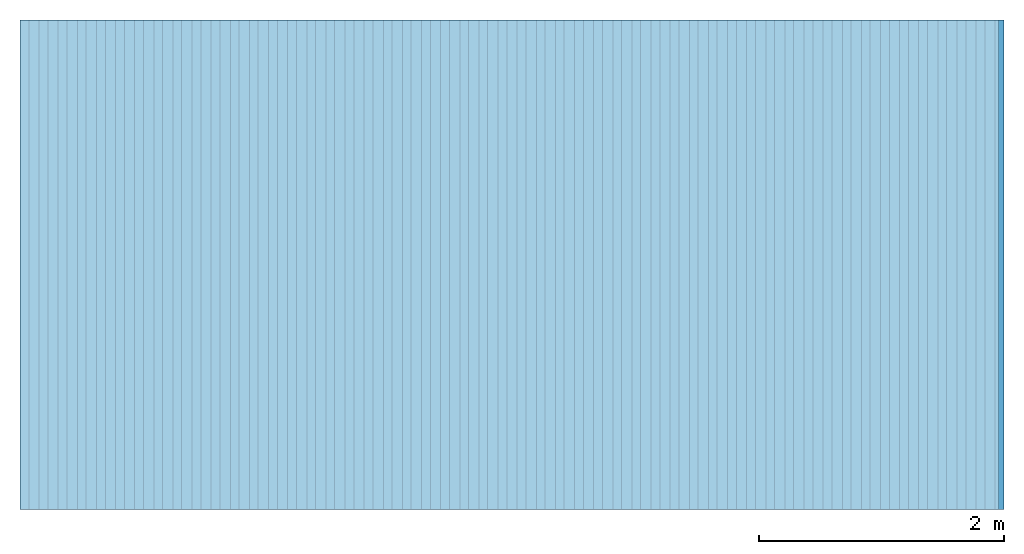
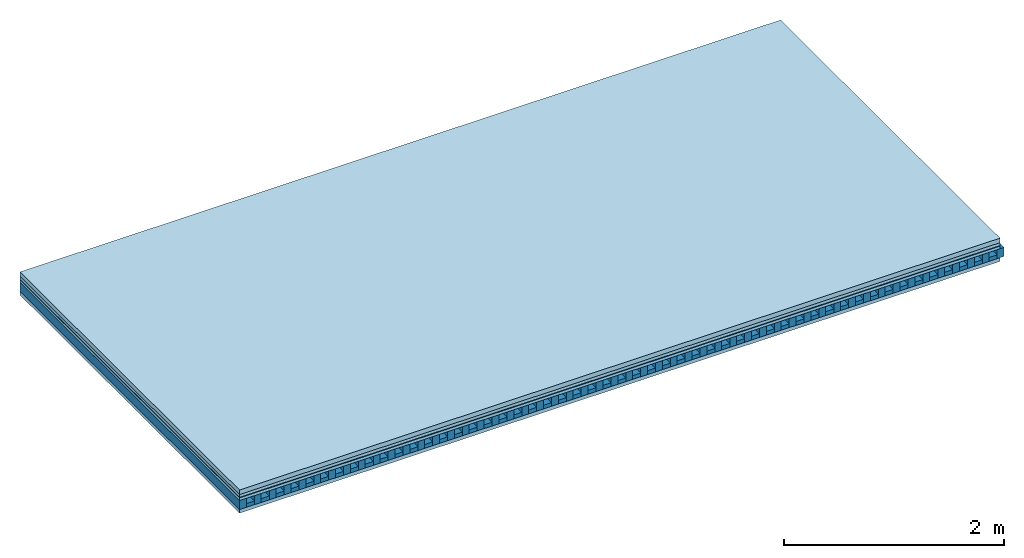
# One storey: 5 plates, 2 members, 1 element without a shape of its own.
"""IFC4 building model written with IfcOpenShell, lengths in metres."""

import ifcopenshell
import ifcopenshell.guid

model = None  # the IFC model being written
_history = None  # IfcOwnerHistory: only IFC2X3 demands one
_inside = {}  # id of a spatial element -> (the spatial element, [elements in it])
_under = {}  # id of a project, library or spatial element -> (it, [spatial elements below it])
_declared = {}  # id of a project -> (the project, [libraries it declares])
_typed = {}  # id of a type object -> (the type object, [elements of that type])
_made_of = {}  # id of a material, layer set ... -> (it, [elements and type objects made of it])


def new_model(schema):
    """Start an empty IFC model of exactly this schema.

    Asked for "IFC4X3", IfcOpenShell would pick the latest addendum, in which some entities
    have other attributes; the version numbers below select the first issue.
    IFC2X3 requires an IfcOwnerHistory on every rooted entity: one is made here for all.
    """
    global model, _history
    if schema == "IFC4X3":
        model = ifcopenshell.file(schema_version=(4, 3, 0, 0))
    else:
        model = ifcopenshell.file(schema=schema)
    _inside.clear()
    _under.clear()
    _declared.clear()
    _typed.clear()
    _made_of.clear()
    _history = None
    if model.schema == "IFC2X3":
        org = make("IfcOrganization", Name="unknown")
        user = make(
            "IfcPersonAndOrganization",
            ThePerson=make("IfcPerson", FamilyName="unknown"),
            TheOrganization=org,
        )
        app = make(
            "IfcApplication",
            ApplicationDeveloper=org,
            Version="unknown",
            ApplicationFullName="unknown",
            ApplicationIdentifier="unknown",
        )
        _history = make(
            "IfcOwnerHistory",
            OwningUser=user,
            OwningApplication=app,
            ChangeAction="ADDED",
            CreationDate=0,
        )
    return model


def make(cls, **values):
    """One entity of the class cls with the attributes given. An attribute that is None is left unset."""
    return model.create_entity(
        cls, **{name: value for name, value in values.items() if value is not None}
    )


def rooted(cls, **values):
    """An entity with a GlobalId (a new one), such as an element, a storey or a relation."""
    return make(cls, GlobalId=ifcopenshell.guid.new(), OwnerHistory=_history, **values)


def si_unit(unit_type, name, prefix=None):
    """IfcSIUnit, for example si_unit("LENGTHUNIT", "METRE", prefix="MILLI")."""
    return make("IfcSIUnit", UnitType=unit_type, Prefix=prefix, Name=name)


def derived_unit(unit_type, elements):
    """IfcDerivedUnit: a product of units, each with its exponent."""
    return make(
        "IfcDerivedUnit",
        Elements=[
            make("IfcDerivedUnitElement", Unit=unit, Exponent=power)
            for unit, power in elements
        ],
        UnitType=unit_type,
    )


def assignment(units):
    """IfcUnitAssignment: the units of a project."""
    return None if units is None else make("IfcUnitAssignment", Units=units)


def point(xyz):
    """IfcCartesianPoint."""
    return None if xyz is None else make("IfcCartesianPoint", Coordinates=xyz)


def direction(xyz):
    """IfcDirection."""
    return None if xyz is None else make("IfcDirection", DirectionRatios=xyz)


def frame(location, z_axis=None, x_axis=None):
    """IfcAxis2Placement3D, a coordinate frame: its origin and axes. An axis left out is left unset."""
    return make(
        "IfcAxis2Placement3D",
        Location=point(location),
        Axis=direction(z_axis),
        RefDirection=direction(x_axis),
    )


def frame_2d(location, x_axis=None):
    """IfcAxis2Placement2D, a coordinate frame in the plane: its origin and x axis."""
    return make(
        "IfcAxis2Placement2D", Location=point(location), RefDirection=direction(x_axis)
    )


def origin():
    """The frame at (0, 0, 0) with its axes left unset."""
    return frame((0.0, 0.0, 0.0))


def origin_with_axes():
    """The frame at (0, 0, 0) with the z axis (0, 0, 1) and the x axis (1, 0, 0) written out."""
    return frame((0.0, 0.0, 0.0), z_axis=(0.0, 0.0, 1.0), x_axis=(1.0, 0.0, 0.0))


def place(relative_to, where):
    """IfcLocalPlacement: puts the frame where relative to a parent placement (None: the world)."""
    return make(
        "IfcLocalPlacement", PlacementRelTo=relative_to, RelativePlacement=where
    )


def context(
    kind, dimensions, precision=None, world=None, true_north=None, identifier=None
):
    """IfcGeometricRepresentationContext, for example the 3D "Model" context."""
    return make(
        "IfcGeometricRepresentationContext",
        ContextIdentifier=identifier,
        ContextType=kind,
        CoordinateSpaceDimension=dimensions,
        Precision=precision,
        WorldCoordinateSystem=world,
        TrueNorth=true_north,
    )


def project(units=None, contexts=None):
    """IfcProject with its units and contexts."""
    return rooted(
        "IfcProject",
        Name="project",
        RepresentationContexts=contexts,
        UnitsInContext=assignment(units),
    )


def spatial(cls, under=None, at=None, **own):
    """A site, building, storey or space (cls), placed at a placement, below another one or the project."""
    s = rooted(cls, ObjectPlacement=at, **own)
    if under is not None:
        _under.setdefault(under.id(), (under, []))[1].append(s)
    return s


def profile(cls, at=None, kind="AREA", **sizes):
    """A parametric profile (cls). Its sizes go by their IFC names, for example OverallWidth=200.0."""
    return make(cls, ProfileType=kind, Position=at, **sizes)


def rectangle(**sizes):
    """IfcRectangleProfileDef."""
    return profile("IfcRectangleProfileDef", **sizes)


def extrude(swept, where, along, depth):
    """IfcExtrudedAreaSolid: the profile swept, set in the frame where, extruded along a direction by depth."""
    return make(
        "IfcExtrudedAreaSolid",
        SweptArea=swept,
        Position=where,
        ExtrudedDirection=direction(along),
        Depth=depth,
    )


def shape(context_of_items, identifier, shape_type, items):
    """IfcShapeRepresentation: the items that make up one representation, for example the "Body"."""
    return make(
        "IfcShapeRepresentation",
        ContextOfItems=context_of_items,
        RepresentationIdentifier=identifier,
        RepresentationType=shape_type,
        Items=items,
    )


def material(Name=None, Category=None):
    """IfcMaterial."""
    return make("IfcMaterial", Name=Name, Category=Category)


def layer(
    of_material, thickness, ventilated=None, Name=None, Category=None, Priority=None
):
    """IfcMaterialLayer: one layer of a wall or slab, of a material (None: an air gap)."""
    return make(
        "IfcMaterialLayer",
        Material=of_material,
        LayerThickness=thickness,
        IsVentilated=ventilated,
        Name=Name,
        Category=Category,
        Priority=Priority,
    )


def layer_set(layers, Name=None):
    """IfcMaterialLayerSet."""
    return make("IfcMaterialLayerSet", MaterialLayers=layers, LayerSetName=Name)


def made_of(thing, what):
    """Note that an element or type object is made of a material, layer set ...; save() writes the relation."""
    if what is not None:
        _made_of.setdefault(what.id(), (what, []))[1].append(thing)
    return thing


def type_object(cls, material=None, **own):
    """A type object (cls), such as IfcWallType, which elements share."""
    return made_of(rooted(cls, **own), material)


def element(
    cls,
    number,
    at=None,
    inside=None,
    cuts=None,
    type_object=None,
    material=None,
    context=None,
    identifier="Body",
    shape_type=None,
    held_by="IfcProductDefinitionShape",
    body=None,
    shapes=None,
    **own,
):
    """One element of the class cls, such as IfcWall. Its Tag is "e" and its number.

    at: its placement. inside: the storey or other place that contains it. cuts: it is an
    opening in that element (IfcRelVoidsElement). A single representation is given by context,
    identifier, shape_type and body (its items); several are given by shapes. held_by: the class
    of the entity that holds the representations. save() writes the other relations.
    """
    e = rooted(cls, Tag="e%d" % number, ObjectPlacement=at, **own)
    if body is not None:
        shapes = [shape(context, identifier, shape_type, body)]
    if shapes is not None:
        e.Representation = make(held_by, Representations=shapes)
    if inside is not None:
        _inside.setdefault(inside.id(), (inside, []))[1].append(e)
    if cuts is not None:
        rooted(
            "IfcRelVoidsElement", RelatingBuildingElement=cuts, RelatedOpeningElement=e
        )
    if type_object is not None:
        _typed.setdefault(type_object.id(), (type_object, []))[1].append(e)
    return made_of(e, material)


def aggregate(whole, parts):
    """IfcRelAggregates: a whole, such as a stair, and the parts it consists of."""
    return rooted("IfcRelAggregates", RelatingObject=whole, RelatedObjects=parts)


def save(model, path):
    """Write the relations noted so far, then the file.

    IfcRelAggregates (storeys below a building ...), IfcRelContainedInSpatialStructure (elements
    in a storey), IfcRelDefinesByType, IfcRelAssociatesMaterial and IfcRelDeclares: one each for
    every whole, place, type object, material and project.
    """
    for whole, parts in _under.values():
        aggregate(whole, parts)
    for where, things in _inside.values():
        rooted(
            "IfcRelContainedInSpatialStructure",
            RelatedElements=things,
            RelatingStructure=where,
        )
    for kind, things in _typed.values():
        rooted("IfcRelDefinesByType", RelatedObjects=things, RelatingType=kind)
    for what, things in _made_of.values():
        rooted("IfcRelAssociatesMaterial", RelatedObjects=things, RelatingMaterial=what)
    for by, libraries in _declared.values():
        rooted("IfcRelDeclares", RelatingContext=by, RelatedDefinitions=libraries)
    model.write(path)


model = new_model("IFC4")

# Units and contexts
plan_context = context("Plan", 3, precision=1e-05, world=origin(), true_north=direction((0.0, 1.0)))
model_context = context("Model", 3, precision=1e-05, world=origin(), true_north=direction((0.0, 1.0)))
ifc_project = project(units=[si_unit("LENGTHUNIT", "METRE"), derived_unit("SOUNDPRESSUREUNIT", [(si_unit("PRESSUREUNIT", "PASCAL", prefix="MICRO"), 0)]), si_unit("ENERGYUNIT", "JOULE", prefix="MEGA"), si_unit("MASSUNIT", "GRAM", prefix="KILO"), derived_unit("THERMALTRANSMITTANCEUNIT", [(si_unit("POWERUNIT", "WATT"), 1), (si_unit("AREAUNIT", "SQUARE_METRE"), -1), (si_unit("THERMODYNAMICTEMPERATUREUNIT", "KELVIN"), -1)]), derived_unit("AREADENSITYUNIT", [(si_unit("MASSUNIT", "GRAM", prefix="KILO"), 1), (si_unit("AREAUNIT", "SQUARE_METRE"), -1)]), derived_unit("USERDEFINED", [(si_unit("ENERGYUNIT", "JOULE", prefix="MEGA"), 1), (si_unit("AREAUNIT", "SQUARE_METRE"), -1)])], contexts=[plan_context, model_context])

# Site, building, storey
site = spatial("IfcSite", under=ifc_project)
building_placement = place(None, origin())
building = spatial("IfcBuilding", under=site, at=building_placement)
storey_placement = place(building_placement, origin())
storey = spatial("IfcBuildingStorey", under=building, at=storey_placement)

# Slab, members, plates
ifc_material_1 = material(Name="Cement screed", Category="04.006")
ifc_layer_1 = layer(ifc_material_1, 0.05, Name="On-material")
ifc_material_2 = material(Name="32/30mm", Category="10.009")
ifc_layer_2 = layer(ifc_material_2, 0.032, Name="Impact sound insulation")
ifc_material_3 = material(Name="Step 6mm", Category="10.009")
ifc_layer_3 = layer(ifc_material_3, 0.006, Name="Additional insulation")
ifc_material_4 = material()
ifc_layer_4 = layer(ifc_material_4, 0.03, Name="Sub-floor")
ifc_material_5 = material(Name="Rigid, of the art")
ifc_layer_5 = layer(ifc_material_5, 0.0, Name="Bond")
ifc_layer_6 = layer(None, 0.1, Name="Supporting structure")
ifc_layer_7 = layer(ifc_material_5, 0.0, Name="Bond")
ifc_material_6 = material(Name="panel on the underside HBF 40mm (20+20mm)", Category="07.001")
ifc_layer_8 = layer(ifc_material_6, 0.04, Name="Lower layer 1")
ifc_layer_set = layer_set([ifc_layer_1, ifc_layer_2, ifc_layer_3, ifc_layer_4, ifc_layer_5, ifc_layer_6, ifc_layer_7, ifc_layer_8])
slab_type = type_object("IfcSlabType", Name="A0087", PredefinedType="NOTDEFINED", material=ifc_layer_set)
slab_placement = place(None, frame((0.0, 0.0, 0.0), z_axis=(0.0, 0.0, -1.0), x_axis=(1.0, 0.0, 0.0)))
slab = element("IfcSlab", 1, at=slab_placement, inside=storey, type_object=slab_type, material=ifc_layer_set, Name="Slab #1")
ifc_material_7 = material(Name="Block Q4")
member_1_placement = place(slab_placement, origin())
member_1 = element("IfcMember", 2, at=member_1_placement, material=ifc_material_7, Name="Supporting structure", context=plan_context, shape_type="SweptSolid", body=[
    extrude(rectangle(XDim=0.071666666666667, YDim=0.1, at=frame_2d((0.0358333333333335, 0.05), x_axis=(1.0, 0.0))), frame((0.0, 4.0, 0.118), z_axis=(0.0, -1.0, 0.0), x_axis=(1.0, 0.0, 0.0)), (0.0, 0.0, 1.0), 4.0),
    extrude(rectangle(XDim=0.071666666666667, YDim=0.1, at=frame_2d((0.0358333333333335, 0.05), x_axis=(1.0, 0.0))), frame((0.15625, 4.0, 0.118), z_axis=(0.0, -1.0, 0.0), x_axis=(1.0, 0.0, 0.0)), (0.0, 0.0, 1.0), 4.0),
    extrude(rectangle(XDim=0.071666666666667, YDim=0.1, at=frame_2d((0.0358333333333335, 0.05), x_axis=(1.0, 0.0))), frame((0.3125, 4.0, 0.118), z_axis=(0.0, -1.0, 0.0), x_axis=(1.0, 0.0, 0.0)), (0.0, 0.0, 1.0), 4.0),
    extrude(rectangle(XDim=0.071666666666667, YDim=0.1, at=frame_2d((0.0358333333333335, 0.05), x_axis=(1.0, 0.0))), frame((0.46875, 4.0, 0.118), z_axis=(0.0, -1.0, 0.0), x_axis=(1.0, 0.0, 0.0)), (0.0, 0.0, 1.0), 4.0),
    extrude(rectangle(XDim=0.071666666666667, YDim=0.1, at=frame_2d((0.0358333333333335, 0.05), x_axis=(1.0, 0.0))), frame((0.625, 4.0, 0.118), z_axis=(0.0, -1.0, 0.0), x_axis=(1.0, 0.0, 0.0)), (0.0, 0.0, 1.0), 4.0),
    extrude(rectangle(XDim=0.071666666666667, YDim=0.1, at=frame_2d((0.0358333333333335, 0.05), x_axis=(1.0, 0.0))), frame((0.78125, 4.0, 0.118), z_axis=(0.0, -1.0, 0.0), x_axis=(1.0, 0.0, 0.0)), (0.0, 0.0, 1.0), 4.0),
    extrude(rectangle(XDim=0.071666666666667, YDim=0.1, at=frame_2d((0.0358333333333335, 0.05), x_axis=(1.0, 0.0))), frame((0.9375, 4.0, 0.118), z_axis=(0.0, -1.0, 0.0), x_axis=(1.0, 0.0, 0.0)), (0.0, 0.0, 1.0), 4.0),
    extrude(rectangle(XDim=0.071666666666667, YDim=0.1, at=frame_2d((0.0358333333333335, 0.05), x_axis=(1.0, 0.0))), frame((1.09375, 4.0, 0.118), z_axis=(0.0, -1.0, 0.0), x_axis=(1.0, 0.0, 0.0)), (0.0, 0.0, 1.0), 4.0),
    extrude(rectangle(XDim=0.071666666666667, YDim=0.1, at=frame_2d((0.0358333333333335, 0.05), x_axis=(1.0, 0.0))), frame((1.25, 4.0, 0.118), z_axis=(0.0, -1.0, 0.0), x_axis=(1.0, 0.0, 0.0)), (0.0, 0.0, 1.0), 4.0),
    extrude(rectangle(XDim=0.071666666666667, YDim=0.1, at=frame_2d((0.0358333333333335, 0.05), x_axis=(1.0, 0.0))), frame((1.40625, 4.0, 0.118), z_axis=(0.0, -1.0, 0.0), x_axis=(1.0, 0.0, 0.0)), (0.0, 0.0, 1.0), 4.0),
    extrude(rectangle(XDim=0.071666666666667, YDim=0.1, at=frame_2d((0.0358333333333335, 0.05), x_axis=(1.0, 0.0))), frame((1.5625, 4.0, 0.118), z_axis=(0.0, -1.0, 0.0), x_axis=(1.0, 0.0, 0.0)), (0.0, 0.0, 1.0), 4.0),
    extrude(rectangle(XDim=0.071666666666667, YDim=0.1, at=frame_2d((0.0358333333333335, 0.05), x_axis=(1.0, 0.0))), frame((1.71875, 4.0, 0.118), z_axis=(0.0, -1.0, 0.0), x_axis=(1.0, 0.0, 0.0)), (0.0, 0.0, 1.0), 4.0),
    extrude(rectangle(XDim=0.071666666666667, YDim=0.1, at=frame_2d((0.0358333333333335, 0.05), x_axis=(1.0, 0.0))), frame((1.875, 4.0, 0.118), z_axis=(0.0, -1.0, 0.0), x_axis=(1.0, 0.0, 0.0)), (0.0, 0.0, 1.0), 4.0),
    extrude(rectangle(XDim=0.071666666666667, YDim=0.1, at=frame_2d((0.0358333333333335, 0.05), x_axis=(1.0, 0.0))), frame((2.03125, 4.0, 0.118), z_axis=(0.0, -1.0, 0.0), x_axis=(1.0, 0.0, 0.0)), (0.0, 0.0, 1.0), 4.0),
    extrude(rectangle(XDim=0.071666666666667, YDim=0.1, at=frame_2d((0.0358333333333335, 0.05), x_axis=(1.0, 0.0))), frame((2.1875, 4.0, 0.118), z_axis=(0.0, -1.0, 0.0), x_axis=(1.0, 0.0, 0.0)), (0.0, 0.0, 1.0), 4.0),
    extrude(rectangle(XDim=0.071666666666667, YDim=0.1, at=frame_2d((0.0358333333333335, 0.05), x_axis=(1.0, 0.0))), frame((2.34375, 4.0, 0.118), z_axis=(0.0, -1.0, 0.0), x_axis=(1.0, 0.0, 0.0)), (0.0, 0.0, 1.0), 4.0),
    extrude(rectangle(XDim=0.071666666666667, YDim=0.1, at=frame_2d((0.0358333333333335, 0.05), x_axis=(1.0, 0.0))), frame((2.5, 4.0, 0.118), z_axis=(0.0, -1.0, 0.0), x_axis=(1.0, 0.0, 0.0)), (0.0, 0.0, 1.0), 4.0),
    extrude(rectangle(XDim=0.071666666666667, YDim=0.1, at=frame_2d((0.0358333333333335, 0.05), x_axis=(1.0, 0.0))), frame((2.65625, 4.0, 0.118), z_axis=(0.0, -1.0, 0.0), x_axis=(1.0, 0.0, 0.0)), (0.0, 0.0, 1.0), 4.0),
    extrude(rectangle(XDim=0.071666666666667, YDim=0.1, at=frame_2d((0.0358333333333335, 0.05), x_axis=(1.0, 0.0))), frame((2.8125, 4.0, 0.118), z_axis=(0.0, -1.0, 0.0), x_axis=(1.0, 0.0, 0.0)), (0.0, 0.0, 1.0), 4.0),
    extrude(rectangle(XDim=0.071666666666667, YDim=0.1, at=frame_2d((0.0358333333333335, 0.05), x_axis=(1.0, 0.0))), frame((2.96875, 4.0, 0.118), z_axis=(0.0, -1.0, 0.0), x_axis=(1.0, 0.0, 0.0)), (0.0, 0.0, 1.0), 4.0),
    extrude(rectangle(XDim=0.071666666666667, YDim=0.1, at=frame_2d((0.0358333333333335, 0.05), x_axis=(1.0, 0.0))), frame((3.125, 4.0, 0.118), z_axis=(0.0, -1.0, 0.0), x_axis=(1.0, 0.0, 0.0)), (0.0, 0.0, 1.0), 4.0),
    extrude(rectangle(XDim=0.071666666666667, YDim=0.1, at=frame_2d((0.0358333333333335, 0.05), x_axis=(1.0, 0.0))), frame((3.28125, 4.0, 0.118), z_axis=(0.0, -1.0, 0.0), x_axis=(1.0, 0.0, 0.0)), (0.0, 0.0, 1.0), 4.0),
    extrude(rectangle(XDim=0.071666666666667, YDim=0.1, at=frame_2d((0.0358333333333335, 0.05), x_axis=(1.0, 0.0))), frame((3.4375, 4.0, 0.118), z_axis=(0.0, -1.0, 0.0), x_axis=(1.0, 0.0, 0.0)), (0.0, 0.0, 1.0), 4.0),
    extrude(rectangle(XDim=0.071666666666667, YDim=0.1, at=frame_2d((0.0358333333333335, 0.05), x_axis=(1.0, 0.0))), frame((3.59375, 4.0, 0.118), z_axis=(0.0, -1.0, 0.0), x_axis=(1.0, 0.0, 0.0)), (0.0, 0.0, 1.0), 4.0),
    extrude(rectangle(XDim=0.071666666666667, YDim=0.1, at=frame_2d((0.0358333333333335, 0.05), x_axis=(1.0, 0.0))), frame((3.75, 4.0, 0.118), z_axis=(0.0, -1.0, 0.0), x_axis=(1.0, 0.0, 0.0)), (0.0, 0.0, 1.0), 4.0),
    extrude(rectangle(XDim=0.071666666666667, YDim=0.1, at=frame_2d((0.0358333333333335, 0.05), x_axis=(1.0, 0.0))), frame((3.90625, 4.0, 0.118), z_axis=(0.0, -1.0, 0.0), x_axis=(1.0, 0.0, 0.0)), (0.0, 0.0, 1.0), 4.0),
    extrude(rectangle(XDim=0.071666666666667, YDim=0.1, at=frame_2d((0.0358333333333335, 0.05), x_axis=(1.0, 0.0))), frame((4.0625, 4.0, 0.118), z_axis=(0.0, -1.0, 0.0), x_axis=(1.0, 0.0, 0.0)), (0.0, 0.0, 1.0), 4.0),
    extrude(rectangle(XDim=0.071666666666667, YDim=0.1, at=frame_2d((0.0358333333333335, 0.05), x_axis=(1.0, 0.0))), frame((4.21875, 4.0, 0.118), z_axis=(0.0, -1.0, 0.0), x_axis=(1.0, 0.0, 0.0)), (0.0, 0.0, 1.0), 4.0),
    extrude(rectangle(XDim=0.071666666666667, YDim=0.1, at=frame_2d((0.0358333333333335, 0.05), x_axis=(1.0, 0.0))), frame((4.375, 4.0, 0.118), z_axis=(0.0, -1.0, 0.0), x_axis=(1.0, 0.0, 0.0)), (0.0, 0.0, 1.0), 4.0),
    extrude(rectangle(XDim=0.071666666666667, YDim=0.1, at=frame_2d((0.0358333333333335, 0.05), x_axis=(1.0, 0.0))), frame((4.53125, 4.0, 0.118), z_axis=(0.0, -1.0, 0.0), x_axis=(1.0, 0.0, 0.0)), (0.0, 0.0, 1.0), 4.0),
    extrude(rectangle(XDim=0.071666666666667, YDim=0.1, at=frame_2d((0.0358333333333335, 0.05), x_axis=(1.0, 0.0))), frame((4.6875, 4.0, 0.118), z_axis=(0.0, -1.0, 0.0), x_axis=(1.0, 0.0, 0.0)), (0.0, 0.0, 1.0), 4.0),
    extrude(rectangle(XDim=0.071666666666667, YDim=0.1, at=frame_2d((0.0358333333333335, 0.05), x_axis=(1.0, 0.0))), frame((4.84375, 4.0, 0.118), z_axis=(0.0, -1.0, 0.0), x_axis=(1.0, 0.0, 0.0)), (0.0, 0.0, 1.0), 4.0),
    extrude(rectangle(XDim=0.071666666666667, YDim=0.1, at=frame_2d((0.0358333333333335, 0.05), x_axis=(1.0, 0.0))), frame((5.0, 4.0, 0.118), z_axis=(0.0, -1.0, 0.0), x_axis=(1.0, 0.0, 0.0)), (0.0, 0.0, 1.0), 4.0),
    extrude(rectangle(XDim=0.071666666666667, YDim=0.1, at=frame_2d((0.0358333333333335, 0.05), x_axis=(1.0, 0.0))), frame((5.15625, 4.0, 0.118), z_axis=(0.0, -1.0, 0.0), x_axis=(1.0, 0.0, 0.0)), (0.0, 0.0, 1.0), 4.0),
    extrude(rectangle(XDim=0.071666666666667, YDim=0.1, at=frame_2d((0.0358333333333335, 0.05), x_axis=(1.0, 0.0))), frame((5.3125, 4.0, 0.118), z_axis=(0.0, -1.0, 0.0), x_axis=(1.0, 0.0, 0.0)), (0.0, 0.0, 1.0), 4.0),
    extrude(rectangle(XDim=0.071666666666667, YDim=0.1, at=frame_2d((0.0358333333333335, 0.05), x_axis=(1.0, 0.0))), frame((5.46875, 4.0, 0.118), z_axis=(0.0, -1.0, 0.0), x_axis=(1.0, 0.0, 0.0)), (0.0, 0.0, 1.0), 4.0),
    extrude(rectangle(XDim=0.071666666666667, YDim=0.1, at=frame_2d((0.0358333333333335, 0.05), x_axis=(1.0, 0.0))), frame((5.625, 4.0, 0.118), z_axis=(0.0, -1.0, 0.0), x_axis=(1.0, 0.0, 0.0)), (0.0, 0.0, 1.0), 4.0),
    extrude(rectangle(XDim=0.071666666666667, YDim=0.1, at=frame_2d((0.0358333333333335, 0.05), x_axis=(1.0, 0.0))), frame((5.78125, 4.0, 0.118), z_axis=(0.0, -1.0, 0.0), x_axis=(1.0, 0.0, 0.0)), (0.0, 0.0, 1.0), 4.0),
    extrude(rectangle(XDim=0.071666666666667, YDim=0.1, at=frame_2d((0.0358333333333335, 0.05), x_axis=(1.0, 0.0))), frame((5.9375, 4.0, 0.118), z_axis=(0.0, -1.0, 0.0), x_axis=(1.0, 0.0, 0.0)), (0.0, 0.0, 1.0), 4.0),
    extrude(rectangle(XDim=0.071666666666667, YDim=0.1, at=frame_2d((0.0358333333333335, 0.05), x_axis=(1.0, 0.0))), frame((6.09375, 4.0, 0.118), z_axis=(0.0, -1.0, 0.0), x_axis=(1.0, 0.0, 0.0)), (0.0, 0.0, 1.0), 4.0),
    extrude(rectangle(XDim=0.071666666666667, YDim=0.1, at=frame_2d((0.0358333333333335, 0.05), x_axis=(1.0, 0.0))), frame((6.25, 4.0, 0.118), z_axis=(0.0, -1.0, 0.0), x_axis=(1.0, 0.0, 0.0)), (0.0, 0.0, 1.0), 4.0),
    extrude(rectangle(XDim=0.071666666666667, YDim=0.1, at=frame_2d((0.0358333333333335, 0.05), x_axis=(1.0, 0.0))), frame((6.40625, 4.0, 0.118), z_axis=(0.0, -1.0, 0.0), x_axis=(1.0, 0.0, 0.0)), (0.0, 0.0, 1.0), 4.0),
    extrude(rectangle(XDim=0.071666666666667, YDim=0.1, at=frame_2d((0.0358333333333335, 0.05), x_axis=(1.0, 0.0))), frame((6.5625, 4.0, 0.118), z_axis=(0.0, -1.0, 0.0), x_axis=(1.0, 0.0, 0.0)), (0.0, 0.0, 1.0), 4.0),
    extrude(rectangle(XDim=0.071666666666667, YDim=0.1, at=frame_2d((0.0358333333333335, 0.05), x_axis=(1.0, 0.0))), frame((6.71875, 4.0, 0.118), z_axis=(0.0, -1.0, 0.0), x_axis=(1.0, 0.0, 0.0)), (0.0, 0.0, 1.0), 4.0),
    extrude(rectangle(XDim=0.071666666666667, YDim=0.1, at=frame_2d((0.0358333333333335, 0.05), x_axis=(1.0, 0.0))), frame((6.875, 4.0, 0.118), z_axis=(0.0, -1.0, 0.0), x_axis=(1.0, 0.0, 0.0)), (0.0, 0.0, 1.0), 4.0),
    extrude(rectangle(XDim=0.071666666666667, YDim=0.1, at=frame_2d((0.0358333333333335, 0.05), x_axis=(1.0, 0.0))), frame((7.03125, 4.0, 0.118), z_axis=(0.0, -1.0, 0.0), x_axis=(1.0, 0.0, 0.0)), (0.0, 0.0, 1.0), 4.0),
    extrude(rectangle(XDim=0.071666666666667, YDim=0.1, at=frame_2d((0.0358333333333335, 0.05), x_axis=(1.0, 0.0))), frame((7.1875, 4.0, 0.118), z_axis=(0.0, -1.0, 0.0), x_axis=(1.0, 0.0, 0.0)), (0.0, 0.0, 1.0), 4.0),
    extrude(rectangle(XDim=0.071666666666667, YDim=0.1, at=frame_2d((0.0358333333333335, 0.05), x_axis=(1.0, 0.0))), frame((7.34375, 4.0, 0.118), z_axis=(0.0, -1.0, 0.0), x_axis=(1.0, 0.0, 0.0)), (0.0, 0.0, 1.0), 4.0),
    extrude(rectangle(XDim=0.071666666666667, YDim=0.1, at=frame_2d((0.0358333333333335, 0.05), x_axis=(1.0, 0.0))), frame((7.5, 4.0, 0.118), z_axis=(0.0, -1.0, 0.0), x_axis=(1.0, 0.0, 0.0)), (0.0, 0.0, 1.0), 4.0),
    extrude(rectangle(XDim=0.071666666666667, YDim=0.1, at=frame_2d((0.0358333333333335, 0.05), x_axis=(1.0, 0.0))), frame((7.65625, 4.0, 0.118), z_axis=(0.0, -1.0, 0.0), x_axis=(1.0, 0.0, 0.0)), (0.0, 0.0, 1.0), 4.0),
    extrude(rectangle(XDim=0.071666666666667, YDim=0.1, at=frame_2d((0.0358333333333335, 0.05), x_axis=(1.0, 0.0))), frame((7.8125, 4.0, 0.118), z_axis=(0.0, -1.0, 0.0), x_axis=(1.0, 0.0, 0.0)), (0.0, 0.0, 1.0), 4.0),
    extrude(rectangle(XDim=0.071666666666667, YDim=0.1, at=frame_2d((0.0358333333333335, 0.05), x_axis=(1.0, 0.0))), frame((7.96875, 4.0, 0.118), z_axis=(0.0, -1.0, 0.0), x_axis=(1.0, 0.0, 0.0)), (0.0, 0.0, 1.0), 4.0),
])
ifc_material_8 = material()
member_2_placement = place(slab_placement, origin())
member_2 = element("IfcMember", 3, at=member_2_placement, material=ifc_material_8, Name="in supporting structure", context=plan_context, shape_type="SweptSolid", body=[
    extrude(rectangle(XDim=0.084583333333333, YDim=0.042, at=frame_2d((0.0422916666666665, 0.021), x_axis=(1.0, 0.0))), frame((0.071666666666667, 4.0, 0.176), z_axis=(0.0, -1.0, 0.0), x_axis=(1.0, 0.0, 0.0)), (0.0, 0.0, 1.0), 4.0),
    extrude(rectangle(XDim=0.084583333333333, YDim=0.042, at=frame_2d((0.0422916666666665, 0.021), x_axis=(1.0, 0.0))), frame((0.227916666666667, 4.0, 0.176), z_axis=(0.0, -1.0, 0.0), x_axis=(1.0, 0.0, 0.0)), (0.0, 0.0, 1.0), 4.0),
    extrude(rectangle(XDim=0.084583333333333, YDim=0.042, at=frame_2d((0.0422916666666665, 0.021), x_axis=(1.0, 0.0))), frame((0.384166666666667, 4.0, 0.176), z_axis=(0.0, -1.0, 0.0), x_axis=(1.0, 0.0, 0.0)), (0.0, 0.0, 1.0), 4.0),
    extrude(rectangle(XDim=0.084583333333333, YDim=0.042, at=frame_2d((0.0422916666666665, 0.021), x_axis=(1.0, 0.0))), frame((0.540416666666667, 4.0, 0.176), z_axis=(0.0, -1.0, 0.0), x_axis=(1.0, 0.0, 0.0)), (0.0, 0.0, 1.0), 4.0),
    extrude(rectangle(XDim=0.084583333333333, YDim=0.042, at=frame_2d((0.0422916666666665, 0.021), x_axis=(1.0, 0.0))), frame((0.696666666666667, 4.0, 0.176), z_axis=(0.0, -1.0, 0.0), x_axis=(1.0, 0.0, 0.0)), (0.0, 0.0, 1.0), 4.0),
    extrude(rectangle(XDim=0.084583333333333, YDim=0.042, at=frame_2d((0.0422916666666665, 0.021), x_axis=(1.0, 0.0))), frame((0.852916666666667, 4.0, 0.176), z_axis=(0.0, -1.0, 0.0), x_axis=(1.0, 0.0, 0.0)), (0.0, 0.0, 1.0), 4.0),
    extrude(rectangle(XDim=0.084583333333333, YDim=0.042, at=frame_2d((0.0422916666666665, 0.021), x_axis=(1.0, 0.0))), frame((1.00916666666667, 4.0, 0.176), z_axis=(0.0, -1.0, 0.0), x_axis=(1.0, 0.0, 0.0)), (0.0, 0.0, 1.0), 4.0),
    extrude(rectangle(XDim=0.084583333333333, YDim=0.042, at=frame_2d((0.0422916666666665, 0.021), x_axis=(1.0, 0.0))), frame((1.16541666666667, 4.0, 0.176), z_axis=(0.0, -1.0, 0.0), x_axis=(1.0, 0.0, 0.0)), (0.0, 0.0, 1.0), 4.0),
    extrude(rectangle(XDim=0.084583333333333, YDim=0.042, at=frame_2d((0.0422916666666665, 0.021), x_axis=(1.0, 0.0))), frame((1.32166666666667, 4.0, 0.176), z_axis=(0.0, -1.0, 0.0), x_axis=(1.0, 0.0, 0.0)), (0.0, 0.0, 1.0), 4.0),
    extrude(rectangle(XDim=0.084583333333333, YDim=0.042, at=frame_2d((0.0422916666666665, 0.021), x_axis=(1.0, 0.0))), frame((1.47791666666667, 4.0, 0.176), z_axis=(0.0, -1.0, 0.0), x_axis=(1.0, 0.0, 0.0)), (0.0, 0.0, 1.0), 4.0),
    extrude(rectangle(XDim=0.084583333333333, YDim=0.042, at=frame_2d((0.0422916666666665, 0.021), x_axis=(1.0, 0.0))), frame((1.63416666666667, 4.0, 0.176), z_axis=(0.0, -1.0, 0.0), x_axis=(1.0, 0.0, 0.0)), (0.0, 0.0, 1.0), 4.0),
    extrude(rectangle(XDim=0.084583333333333, YDim=0.042, at=frame_2d((0.0422916666666665, 0.021), x_axis=(1.0, 0.0))), frame((1.79041666666667, 4.0, 0.176), z_axis=(0.0, -1.0, 0.0), x_axis=(1.0, 0.0, 0.0)), (0.0, 0.0, 1.0), 4.0),
    extrude(rectangle(XDim=0.084583333333333, YDim=0.042, at=frame_2d((0.0422916666666665, 0.021), x_axis=(1.0, 0.0))), frame((1.94666666666667, 4.0, 0.176), z_axis=(0.0, -1.0, 0.0), x_axis=(1.0, 0.0, 0.0)), (0.0, 0.0, 1.0), 4.0),
    extrude(rectangle(XDim=0.084583333333333, YDim=0.042, at=frame_2d((0.0422916666666665, 0.021), x_axis=(1.0, 0.0))), frame((2.10291666666667, 4.0, 0.176), z_axis=(0.0, -1.0, 0.0), x_axis=(1.0, 0.0, 0.0)), (0.0, 0.0, 1.0), 4.0),
    extrude(rectangle(XDim=0.084583333333333, YDim=0.042, at=frame_2d((0.0422916666666665, 0.021), x_axis=(1.0, 0.0))), frame((2.25916666666667, 4.0, 0.176), z_axis=(0.0, -1.0, 0.0), x_axis=(1.0, 0.0, 0.0)), (0.0, 0.0, 1.0), 4.0),
    extrude(rectangle(XDim=0.084583333333333, YDim=0.042, at=frame_2d((0.0422916666666665, 0.021), x_axis=(1.0, 0.0))), frame((2.41541666666667, 4.0, 0.176), z_axis=(0.0, -1.0, 0.0), x_axis=(1.0, 0.0, 0.0)), (0.0, 0.0, 1.0), 4.0),
    extrude(rectangle(XDim=0.084583333333333, YDim=0.042, at=frame_2d((0.0422916666666665, 0.021), x_axis=(1.0, 0.0))), frame((2.57166666666667, 4.0, 0.176), z_axis=(0.0, -1.0, 0.0), x_axis=(1.0, 0.0, 0.0)), (0.0, 0.0, 1.0), 4.0),
    extrude(rectangle(XDim=0.084583333333333, YDim=0.042, at=frame_2d((0.0422916666666665, 0.021), x_axis=(1.0, 0.0))), frame((2.72791666666667, 4.0, 0.176), z_axis=(0.0, -1.0, 0.0), x_axis=(1.0, 0.0, 0.0)), (0.0, 0.0, 1.0), 4.0),
    extrude(rectangle(XDim=0.084583333333333, YDim=0.042, at=frame_2d((0.0422916666666665, 0.021), x_axis=(1.0, 0.0))), frame((2.88416666666667, 4.0, 0.176), z_axis=(0.0, -1.0, 0.0), x_axis=(1.0, 0.0, 0.0)), (0.0, 0.0, 1.0), 4.0),
    extrude(rectangle(XDim=0.084583333333333, YDim=0.042, at=frame_2d((0.0422916666666665, 0.021), x_axis=(1.0, 0.0))), frame((3.04041666666667, 4.0, 0.176), z_axis=(0.0, -1.0, 0.0), x_axis=(1.0, 0.0, 0.0)), (0.0, 0.0, 1.0), 4.0),
    extrude(rectangle(XDim=0.084583333333333, YDim=0.042, at=frame_2d((0.0422916666666665, 0.021), x_axis=(1.0, 0.0))), frame((3.19666666666667, 4.0, 0.176), z_axis=(0.0, -1.0, 0.0), x_axis=(1.0, 0.0, 0.0)), (0.0, 0.0, 1.0), 4.0),
    extrude(rectangle(XDim=0.084583333333333, YDim=0.042, at=frame_2d((0.0422916666666665, 0.021), x_axis=(1.0, 0.0))), frame((3.35291666666667, 4.0, 0.176), z_axis=(0.0, -1.0, 0.0), x_axis=(1.0, 0.0, 0.0)), (0.0, 0.0, 1.0), 4.0),
    extrude(rectangle(XDim=0.084583333333333, YDim=0.042, at=frame_2d((0.0422916666666665, 0.021), x_axis=(1.0, 0.0))), frame((3.50916666666667, 4.0, 0.176), z_axis=(0.0, -1.0, 0.0), x_axis=(1.0, 0.0, 0.0)), (0.0, 0.0, 1.0), 4.0),
    extrude(rectangle(XDim=0.084583333333333, YDim=0.042, at=frame_2d((0.0422916666666665, 0.021), x_axis=(1.0, 0.0))), frame((3.66541666666667, 4.0, 0.176), z_axis=(0.0, -1.0, 0.0), x_axis=(1.0, 0.0, 0.0)), (0.0, 0.0, 1.0), 4.0),
    extrude(rectangle(XDim=0.084583333333333, YDim=0.042, at=frame_2d((0.0422916666666665, 0.021), x_axis=(1.0, 0.0))), frame((3.82166666666667, 4.0, 0.176), z_axis=(0.0, -1.0, 0.0), x_axis=(1.0, 0.0, 0.0)), (0.0, 0.0, 1.0), 4.0),
    extrude(rectangle(XDim=0.084583333333333, YDim=0.042, at=frame_2d((0.0422916666666665, 0.021), x_axis=(1.0, 0.0))), frame((3.97791666666667, 4.0, 0.176), z_axis=(0.0, -1.0, 0.0), x_axis=(1.0, 0.0, 0.0)), (0.0, 0.0, 1.0), 4.0),
    extrude(rectangle(XDim=0.084583333333333, YDim=0.042, at=frame_2d((0.0422916666666665, 0.021), x_axis=(1.0, 0.0))), frame((4.13416666666667, 4.0, 0.176), z_axis=(0.0, -1.0, 0.0), x_axis=(1.0, 0.0, 0.0)), (0.0, 0.0, 1.0), 4.0),
    extrude(rectangle(XDim=0.084583333333333, YDim=0.042, at=frame_2d((0.0422916666666665, 0.021), x_axis=(1.0, 0.0))), frame((4.29041666666667, 4.0, 0.176), z_axis=(0.0, -1.0, 0.0), x_axis=(1.0, 0.0, 0.0)), (0.0, 0.0, 1.0), 4.0),
    extrude(rectangle(XDim=0.084583333333333, YDim=0.042, at=frame_2d((0.0422916666666665, 0.021), x_axis=(1.0, 0.0))), frame((4.44666666666667, 4.0, 0.176), z_axis=(0.0, -1.0, 0.0), x_axis=(1.0, 0.0, 0.0)), (0.0, 0.0, 1.0), 4.0),
    extrude(rectangle(XDim=0.084583333333333, YDim=0.042, at=frame_2d((0.0422916666666665, 0.021), x_axis=(1.0, 0.0))), frame((4.60291666666667, 4.0, 0.176), z_axis=(0.0, -1.0, 0.0), x_axis=(1.0, 0.0, 0.0)), (0.0, 0.0, 1.0), 4.0),
    extrude(rectangle(XDim=0.084583333333333, YDim=0.042, at=frame_2d((0.0422916666666665, 0.021), x_axis=(1.0, 0.0))), frame((4.75916666666667, 4.0, 0.176), z_axis=(0.0, -1.0, 0.0), x_axis=(1.0, 0.0, 0.0)), (0.0, 0.0, 1.0), 4.0),
    extrude(rectangle(XDim=0.084583333333333, YDim=0.042, at=frame_2d((0.0422916666666665, 0.021), x_axis=(1.0, 0.0))), frame((4.91541666666667, 4.0, 0.176), z_axis=(0.0, -1.0, 0.0), x_axis=(1.0, 0.0, 0.0)), (0.0, 0.0, 1.0), 4.0),
    extrude(rectangle(XDim=0.084583333333333, YDim=0.042, at=frame_2d((0.0422916666666665, 0.021), x_axis=(1.0, 0.0))), frame((5.07166666666667, 4.0, 0.176), z_axis=(0.0, -1.0, 0.0), x_axis=(1.0, 0.0, 0.0)), (0.0, 0.0, 1.0), 4.0),
    extrude(rectangle(XDim=0.084583333333333, YDim=0.042, at=frame_2d((0.0422916666666665, 0.021), x_axis=(1.0, 0.0))), frame((5.22791666666667, 4.0, 0.176), z_axis=(0.0, -1.0, 0.0), x_axis=(1.0, 0.0, 0.0)), (0.0, 0.0, 1.0), 4.0),
    extrude(rectangle(XDim=0.084583333333333, YDim=0.042, at=frame_2d((0.0422916666666665, 0.021), x_axis=(1.0, 0.0))), frame((5.38416666666667, 4.0, 0.176), z_axis=(0.0, -1.0, 0.0), x_axis=(1.0, 0.0, 0.0)), (0.0, 0.0, 1.0), 4.0),
    extrude(rectangle(XDim=0.084583333333333, YDim=0.042, at=frame_2d((0.0422916666666665, 0.021), x_axis=(1.0, 0.0))), frame((5.54041666666667, 4.0, 0.176), z_axis=(0.0, -1.0, 0.0), x_axis=(1.0, 0.0, 0.0)), (0.0, 0.0, 1.0), 4.0),
    extrude(rectangle(XDim=0.084583333333333, YDim=0.042, at=frame_2d((0.0422916666666665, 0.021), x_axis=(1.0, 0.0))), frame((5.69666666666667, 4.0, 0.176), z_axis=(0.0, -1.0, 0.0), x_axis=(1.0, 0.0, 0.0)), (0.0, 0.0, 1.0), 4.0),
    extrude(rectangle(XDim=0.084583333333333, YDim=0.042, at=frame_2d((0.0422916666666665, 0.021), x_axis=(1.0, 0.0))), frame((5.85291666666667, 4.0, 0.176), z_axis=(0.0, -1.0, 0.0), x_axis=(1.0, 0.0, 0.0)), (0.0, 0.0, 1.0), 4.0),
    extrude(rectangle(XDim=0.084583333333333, YDim=0.042, at=frame_2d((0.0422916666666665, 0.021), x_axis=(1.0, 0.0))), frame((6.00916666666667, 4.0, 0.176), z_axis=(0.0, -1.0, 0.0), x_axis=(1.0, 0.0, 0.0)), (0.0, 0.0, 1.0), 4.0),
    extrude(rectangle(XDim=0.084583333333333, YDim=0.042, at=frame_2d((0.0422916666666665, 0.021), x_axis=(1.0, 0.0))), frame((6.16541666666667, 4.0, 0.176), z_axis=(0.0, -1.0, 0.0), x_axis=(1.0, 0.0, 0.0)), (0.0, 0.0, 1.0), 4.0),
    extrude(rectangle(XDim=0.084583333333333, YDim=0.042, at=frame_2d((0.0422916666666665, 0.021), x_axis=(1.0, 0.0))), frame((6.32166666666667, 4.0, 0.176), z_axis=(0.0, -1.0, 0.0), x_axis=(1.0, 0.0, 0.0)), (0.0, 0.0, 1.0), 4.0),
    extrude(rectangle(XDim=0.084583333333333, YDim=0.042, at=frame_2d((0.0422916666666665, 0.021), x_axis=(1.0, 0.0))), frame((6.47791666666667, 4.0, 0.176), z_axis=(0.0, -1.0, 0.0), x_axis=(1.0, 0.0, 0.0)), (0.0, 0.0, 1.0), 4.0),
    extrude(rectangle(XDim=0.084583333333333, YDim=0.042, at=frame_2d((0.0422916666666665, 0.021), x_axis=(1.0, 0.0))), frame((6.63416666666667, 4.0, 0.176), z_axis=(0.0, -1.0, 0.0), x_axis=(1.0, 0.0, 0.0)), (0.0, 0.0, 1.0), 4.0),
    extrude(rectangle(XDim=0.084583333333333, YDim=0.042, at=frame_2d((0.0422916666666665, 0.021), x_axis=(1.0, 0.0))), frame((6.79041666666667, 4.0, 0.176), z_axis=(0.0, -1.0, 0.0), x_axis=(1.0, 0.0, 0.0)), (0.0, 0.0, 1.0), 4.0),
    extrude(rectangle(XDim=0.084583333333333, YDim=0.042, at=frame_2d((0.0422916666666665, 0.021), x_axis=(1.0, 0.0))), frame((6.94666666666667, 4.0, 0.176), z_axis=(0.0, -1.0, 0.0), x_axis=(1.0, 0.0, 0.0)), (0.0, 0.0, 1.0), 4.0),
    extrude(rectangle(XDim=0.084583333333333, YDim=0.042, at=frame_2d((0.0422916666666665, 0.021), x_axis=(1.0, 0.0))), frame((7.10291666666667, 4.0, 0.176), z_axis=(0.0, -1.0, 0.0), x_axis=(1.0, 0.0, 0.0)), (0.0, 0.0, 1.0), 4.0),
    extrude(rectangle(XDim=0.084583333333333, YDim=0.042, at=frame_2d((0.0422916666666665, 0.021), x_axis=(1.0, 0.0))), frame((7.25916666666667, 4.0, 0.176), z_axis=(0.0, -1.0, 0.0), x_axis=(1.0, 0.0, 0.0)), (0.0, 0.0, 1.0), 4.0),
    extrude(rectangle(XDim=0.084583333333333, YDim=0.042, at=frame_2d((0.0422916666666665, 0.021), x_axis=(1.0, 0.0))), frame((7.41541666666667, 4.0, 0.176), z_axis=(0.0, -1.0, 0.0), x_axis=(1.0, 0.0, 0.0)), (0.0, 0.0, 1.0), 4.0),
    extrude(rectangle(XDim=0.084583333333333, YDim=0.042, at=frame_2d((0.0422916666666665, 0.021), x_axis=(1.0, 0.0))), frame((7.57166666666667, 4.0, 0.176), z_axis=(0.0, -1.0, 0.0), x_axis=(1.0, 0.0, 0.0)), (0.0, 0.0, 1.0), 4.0),
    extrude(rectangle(XDim=0.084583333333333, YDim=0.042, at=frame_2d((0.0422916666666665, 0.021), x_axis=(1.0, 0.0))), frame((7.72791666666667, 4.0, 0.176), z_axis=(0.0, -1.0, 0.0), x_axis=(1.0, 0.0, 0.0)), (0.0, 0.0, 1.0), 4.0),
    extrude(rectangle(XDim=0.084583333333333, YDim=0.042, at=frame_2d((0.0422916666666665, 0.021), x_axis=(1.0, 0.0))), frame((7.88416666666667, 4.0, 0.176), z_axis=(0.0, -1.0, 0.0), x_axis=(1.0, 0.0, 0.0)), (0.0, 0.0, 1.0), 4.0),
])
plate_1_placement = place(slab_placement, origin())
plate_1 = element("IfcPlate", 4, at=plate_1_placement, material=ifc_material_1, Name="On-material", context=plan_context, shape_type="SweptSolid", body=[
    extrude(rectangle(XDim=8.0, YDim=4.0, at=frame_2d((4.0, 2.0), x_axis=(1.0, 0.0))), origin_with_axes(), (0.0, 0.0, 1.0), 0.05),
])
plate_2_placement = place(slab_placement, origin())
plate_2 = element("IfcPlate", 5, at=plate_2_placement, material=ifc_material_2, Name="Impact sound insulation", context=plan_context, shape_type="SweptSolid", body=[
    extrude(rectangle(XDim=8.0, YDim=4.0, at=frame_2d((4.0, 2.0), x_axis=(1.0, 0.0))), frame((0.0, 0.0, 0.05), z_axis=(0.0, 0.0, 1.0), x_axis=(1.0, 0.0, 0.0)), (0.0, 0.0, 1.0), 0.032),
])
plate_3_placement = place(slab_placement, origin())
plate_3 = element("IfcPlate", 6, at=plate_3_placement, material=ifc_material_3, Name="Additional insulation", context=plan_context, shape_type="SweptSolid", body=[
    extrude(rectangle(XDim=8.0, YDim=4.0, at=frame_2d((4.0, 2.0), x_axis=(1.0, 0.0))), frame((0.0, 0.0, 0.082), z_axis=(0.0, 0.0, 1.0), x_axis=(1.0, 0.0, 0.0)), (0.0, 0.0, 1.0), 0.006),
])
plate_4_placement = place(slab_placement, origin())
plate_4 = element("IfcPlate", 7, at=plate_4_placement, material=ifc_material_4, Name="Sub-floor", context=plan_context, shape_type="SweptSolid", body=[
    extrude(rectangle(XDim=8.0, YDim=4.0, at=frame_2d((4.0, 2.0), x_axis=(1.0, 0.0))), frame((0.0, 0.0, 0.088), z_axis=(0.0, 0.0, 1.0), x_axis=(1.0, 0.0, 0.0)), (0.0, 0.0, 1.0), 0.03),
])
plate_5_placement = place(slab_placement, origin())
plate_5 = element("IfcPlate", 8, at=plate_5_placement, material=ifc_material_6, Name="Lower layer 1", context=plan_context, shape_type="SweptSolid", body=[
    extrude(rectangle(XDim=8.0, YDim=4.0, at=frame_2d((4.0, 2.0), x_axis=(1.0, 0.0))), frame((0.0, 0.0, 0.218), z_axis=(0.0, 0.0, 1.0), x_axis=(1.0, 0.0, 0.0)), (0.0, 0.0, 1.0), 0.04),
])
aggregate(slab, [plate_1, plate_2, plate_3, plate_4, member_1, member_2, plate_5])

save(model, "model.ifc")
